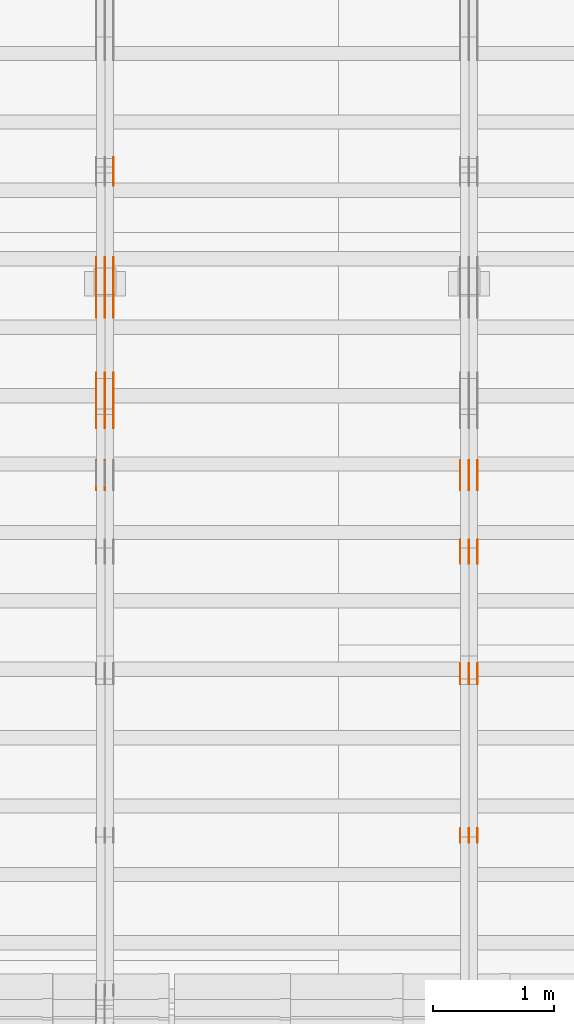
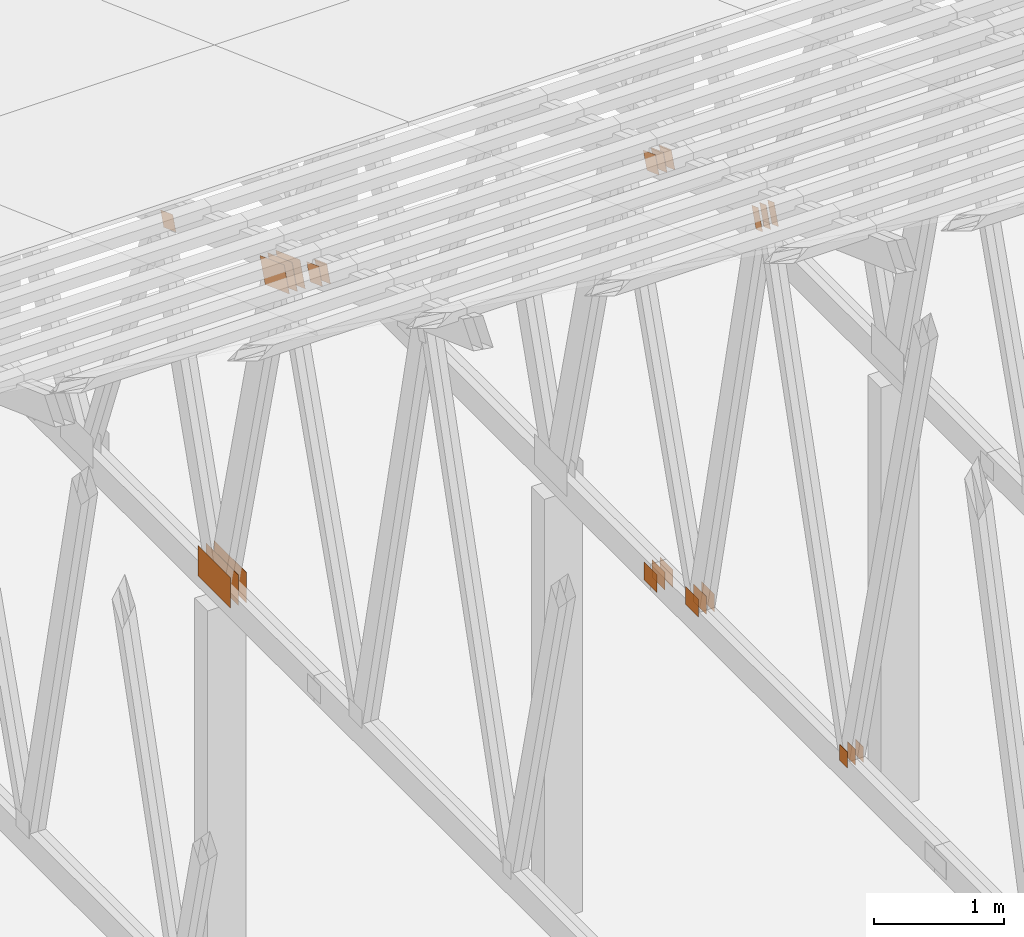
# One storey, part 109 of 189: 31 proxies.
"""IFC2X3 building model written with IfcOpenShell, lengths in millimetres."""

import ifcopenshell
import ifcopenshell.guid

model = None  # the IFC model being written
_history = None  # IfcOwnerHistory: only IFC2X3 demands one
_inside = {}  # id of a spatial element -> (the spatial element, [elements in it])
_under = {}  # id of a project, library or spatial element -> (it, [spatial elements below it])
_declared = {}  # id of a project -> (the project, [libraries it declares])
_typed = {}  # id of a type object -> (the type object, [elements of that type])
_made_of = {}  # id of a material, layer set ... -> (it, [elements and type objects made of it])


def new_model(schema):
    """Start an empty IFC model of exactly this schema.

    Asked for "IFC4X3", IfcOpenShell would pick the latest addendum, in which some entities
    have other attributes; the version numbers below select the first issue.
    IFC2X3 requires an IfcOwnerHistory on every rooted entity: one is made here for all.
    """
    global model, _history
    if schema == "IFC4X3":
        model = ifcopenshell.file(schema_version=(4, 3, 0, 0))
    else:
        model = ifcopenshell.file(schema=schema)
    _inside.clear()
    _under.clear()
    _declared.clear()
    _typed.clear()
    _made_of.clear()
    _history = None
    if model.schema == "IFC2X3":
        org = make("IfcOrganization", Name="unknown")
        user = make(
            "IfcPersonAndOrganization",
            ThePerson=make("IfcPerson", FamilyName="unknown"),
            TheOrganization=org,
        )
        app = make(
            "IfcApplication",
            ApplicationDeveloper=org,
            Version="unknown",
            ApplicationFullName="unknown",
            ApplicationIdentifier="unknown",
        )
        _history = make(
            "IfcOwnerHistory",
            OwningUser=user,
            OwningApplication=app,
            ChangeAction="ADDED",
            CreationDate=0,
        )
    return model


def make(cls, **values):
    """One entity of the class cls with the attributes given. An attribute that is None is left unset."""
    return model.create_entity(
        cls, **{name: value for name, value in values.items() if value is not None}
    )


def entity(cls, *values):
    """Any entity or typed value of the class cls, its attributes in the order of the schema. None: left unset."""
    e = model.create_entity(cls)
    for i, value in enumerate(values):
        if value is not None:
            e[i] = value
    return e


def rooted(cls, **values):
    """An entity with a GlobalId (a new one), such as an element, a storey or a relation."""
    return make(cls, GlobalId=ifcopenshell.guid.new(), OwnerHistory=_history, **values)


def si_unit(unit_type, name, prefix=None):
    """IfcSIUnit, for example si_unit("LENGTHUNIT", "METRE", prefix="MILLI")."""
    return make("IfcSIUnit", UnitType=unit_type, Prefix=prefix, Name=name)


def converted_unit(unit_type, name, factor, base, dimensions=None, offset=None):
    """IfcConversionBasedUnit, such as the inch: factor (a typed value) times the base unit."""
    return make(
        "IfcConversionBasedUnit"
        if offset is None
        else "IfcConversionBasedUnitWithOffset",
        ConversionOffset=offset,
        Dimensions=None
        if dimensions is None
        else entity("IfcDimensionalExponents", *dimensions),
        UnitType=unit_type,
        Name=name,
        ConversionFactor=make(
            "IfcMeasureWithUnit", ValueComponent=factor, UnitComponent=base
        ),
    )


def derived_unit(unit_type, elements):
    """IfcDerivedUnit: a product of units, each with its exponent."""
    return make(
        "IfcDerivedUnit",
        Elements=[
            make("IfcDerivedUnitElement", Unit=unit, Exponent=power)
            for unit, power in elements
        ],
        UnitType=unit_type,
    )


def assignment(units):
    """IfcUnitAssignment: the units of a project."""
    return None if units is None else make("IfcUnitAssignment", Units=units)


def point(xyz):
    """IfcCartesianPoint."""
    return None if xyz is None else make("IfcCartesianPoint", Coordinates=xyz)


def direction(xyz):
    """IfcDirection."""
    return None if xyz is None else make("IfcDirection", DirectionRatios=xyz)


def frame(location, z_axis=None, x_axis=None):
    """IfcAxis2Placement3D, a coordinate frame: its origin and axes. An axis left out is left unset."""
    return make(
        "IfcAxis2Placement3D",
        Location=point(location),
        Axis=direction(z_axis),
        RefDirection=direction(x_axis),
    )


def frame_2d(location, x_axis=None):
    """IfcAxis2Placement2D, a coordinate frame in the plane: its origin and x axis."""
    return make(
        "IfcAxis2Placement2D", Location=point(location), RefDirection=direction(x_axis)
    )


def origin():
    """The frame at (0, 0, 0) with its axes left unset."""
    return frame((0.0, 0.0, 0.0))


def origin_2d_with_axis():
    """The frame at (0, 0) in the plane with the x axis (1, 0) written out."""
    return frame_2d((0.0, 0.0), x_axis=(1.0, 0.0))


def place(relative_to, where):
    """IfcLocalPlacement: puts the frame where relative to a parent placement (None: the world)."""
    return make(
        "IfcLocalPlacement", PlacementRelTo=relative_to, RelativePlacement=where
    )


def context(
    kind, dimensions, precision=None, world=None, true_north=None, identifier=None
):
    """IfcGeometricRepresentationContext, for example the 3D "Model" context."""
    return make(
        "IfcGeometricRepresentationContext",
        ContextIdentifier=identifier,
        ContextType=kind,
        CoordinateSpaceDimension=dimensions,
        Precision=precision,
        WorldCoordinateSystem=world,
        TrueNorth=true_north,
    )


def subcontext(parent, identifier, kind, view, scale=None):
    """IfcGeometricRepresentationSubContext, for example "Body" below "Model"."""
    return make(
        "IfcGeometricRepresentationSubContext",
        ContextIdentifier=identifier,
        ContextType=kind,
        ParentContext=parent,
        TargetScale=scale,
        TargetView=view,
    )


def project(units=None, contexts=None):
    """IfcProject with its units and contexts."""
    return rooted(
        "IfcProject",
        Name="project",
        RepresentationContexts=contexts,
        UnitsInContext=assignment(units),
    )


def spatial(cls, under=None, at=None, **own):
    """A site, building, storey or space (cls), placed at a placement, below another one or the project."""
    s = rooted(cls, ObjectPlacement=at, **own)
    if under is not None:
        _under.setdefault(under.id(), (under, []))[1].append(s)
    return s


def polyline(points):
    """IfcPolyline through the points."""
    return make("IfcPolyline", Points=[point(p) for p in points])


def profile(cls, at=None, kind="AREA", **sizes):
    """A parametric profile (cls). Its sizes go by their IFC names, for example OverallWidth=200.0."""
    return make(cls, ProfileType=kind, Position=at, **sizes)


def rectangle(**sizes):
    """IfcRectangleProfileDef."""
    return profile("IfcRectangleProfileDef", **sizes)


def outline(outer, holes=None, kind="AREA"):
    """IfcArbitraryClosedProfileDef: a profile drawn as a closed curve; with holes, ...WithVoids."""
    if holes is None:
        return make("IfcArbitraryClosedProfileDef", ProfileType=kind, OuterCurve=outer)
    return make(
        "IfcArbitraryProfileDefWithVoids",
        ProfileType=kind,
        OuterCurve=outer,
        InnerCurves=holes,
    )


def extrude(swept, where, along, depth):
    """IfcExtrudedAreaSolid: the profile swept, set in the frame where, extruded along a direction by depth."""
    return make(
        "IfcExtrudedAreaSolid",
        SweptArea=swept,
        Position=where,
        ExtrudedDirection=direction(along),
        Depth=depth,
    )


def shape(context_of_items, identifier, shape_type, items):
    """IfcShapeRepresentation: the items that make up one representation, for example the "Body"."""
    return make(
        "IfcShapeRepresentation",
        ContextOfItems=context_of_items,
        RepresentationIdentifier=identifier,
        RepresentationType=shape_type,
        Items=items,
    )


def source(mapping_origin, context_of_items, identifier, shape_type, items):
    """IfcRepresentationMap: a shape defined once, which mapped items show again and again."""
    return make(
        "IfcRepresentationMap",
        MappingOrigin=mapping_origin,
        MappedRepresentation=shape(context_of_items, identifier, shape_type, items),
    )


def transform(
    local_origin,
    x_axis=None,
    y_axis=None,
    z_axis=None,
    scale=None,
    scale2=None,
    scale3=None,
    uniform=True,
):
    """IfcCartesianTransformationOperator3D, or its non-uniform kind. x_axis, y_axis, z_axis: its Axis1, 2, 3."""
    if uniform:
        return make(
            "IfcCartesianTransformationOperator3D",
            Axis1=direction(x_axis),
            Axis2=direction(y_axis),
            LocalOrigin=point(local_origin),
            Scale=scale,
            Axis3=direction(z_axis),
        )
    return make(
        "IfcCartesianTransformationOperator3DnonUniform",
        Axis1=direction(x_axis),
        Axis2=direction(y_axis),
        LocalOrigin=point(local_origin),
        Scale=scale,
        Axis3=direction(z_axis),
        Scale2=scale2,
        Scale3=scale3,
    )


def mapped(mapping_source, mapping_target):
    """IfcMappedItem: shows the shape of a source again, moved by a transform."""
    return make(
        "IfcMappedItem", MappingSource=mapping_source, MappingTarget=mapping_target
    )


def material(Name=None, Category=None):
    """IfcMaterial."""
    return make("IfcMaterial", Name=Name, Category=Category)


def made_of(thing, what):
    """Note that an element or type object is made of a material, layer set ...; save() writes the relation."""
    if what is not None:
        _made_of.setdefault(what.id(), (what, []))[1].append(thing)
    return thing


def type_object(cls, material=None, **own):
    """A type object (cls), such as IfcWallType, which elements share."""
    return made_of(rooted(cls, **own), material)


def type_shapes(of_type, sources):
    """Give a type object the sources (RepresentationMaps) that its elements show as mapped items."""
    of_type.RepresentationMaps = sources


def element(
    cls,
    number,
    at=None,
    inside=None,
    cuts=None,
    type_object=None,
    material=None,
    context=None,
    identifier="Body",
    shape_type=None,
    held_by="IfcProductDefinitionShape",
    body=None,
    shapes=None,
    **own,
):
    """One element of the class cls, such as IfcWall. Its Tag is "e" and its number.

    at: its placement. inside: the storey or other place that contains it. cuts: it is an
    opening in that element (IfcRelVoidsElement). A single representation is given by context,
    identifier, shape_type and body (its items); several are given by shapes. held_by: the class
    of the entity that holds the representations. save() writes the other relations.
    """
    e = rooted(cls, Tag="e%d" % number, ObjectPlacement=at, **own)
    if body is not None:
        shapes = [shape(context, identifier, shape_type, body)]
    if shapes is not None:
        e.Representation = make(held_by, Representations=shapes)
    if inside is not None:
        _inside.setdefault(inside.id(), (inside, []))[1].append(e)
    if cuts is not None:
        rooted(
            "IfcRelVoidsElement", RelatingBuildingElement=cuts, RelatedOpeningElement=e
        )
    if type_object is not None:
        _typed.setdefault(type_object.id(), (type_object, []))[1].append(e)
    return made_of(e, material)


def aggregate(whole, parts):
    """IfcRelAggregates: a whole, such as a stair, and the parts it consists of."""
    return rooted("IfcRelAggregates", RelatingObject=whole, RelatedObjects=parts)


def save(model, path):
    """Write the relations noted so far, then the file.

    IfcRelAggregates (storeys below a building ...), IfcRelContainedInSpatialStructure (elements
    in a storey), IfcRelDefinesByType, IfcRelAssociatesMaterial and IfcRelDeclares: one each for
    every whole, place, type object, material and project.
    """
    for whole, parts in _under.values():
        aggregate(whole, parts)
    for where, things in _inside.values():
        rooted(
            "IfcRelContainedInSpatialStructure",
            RelatedElements=things,
            RelatingStructure=where,
        )
    for kind, things in _typed.values():
        rooted("IfcRelDefinesByType", RelatedObjects=things, RelatingType=kind)
    for what, things in _made_of.values():
        rooted("IfcRelAssociatesMaterial", RelatedObjects=things, RelatingMaterial=what)
    for by, libraries in _declared.values():
        rooted("IfcRelDeclares", RelatingContext=by, RelatedDefinitions=libraries)
    model.write(path)


model = new_model("IFC2X3")

# Units and contexts
model_context = context("Model", 3, precision=0.01, world=origin(), true_north=direction((6.12303176911189e-17, 1.0)))
body_context = subcontext(model_context, "Body", "Model", "MODEL_VIEW")
ifc_project = project(units=[si_unit("LENGTHUNIT", "METRE", prefix="MILLI"), si_unit("AREAUNIT", "SQUARE_METRE"), si_unit("VOLUMEUNIT", "CUBIC_METRE"), converted_unit("PLANEANGLEUNIT", "DEGREE", entity("IfcRatioMeasure", 0.0174532925199433), si_unit("PLANEANGLEUNIT", "RADIAN"), dimensions=[0, 0, 0, 0, 0, 0, 0]), si_unit("MASSUNIT", "GRAM", prefix="KILO"), derived_unit("MASSDENSITYUNIT", [(si_unit("MASSUNIT", "GRAM", prefix="KILO"), 1), (si_unit("LENGTHUNIT", "METRE"), -3)]), si_unit("TIMEUNIT", "SECOND"), si_unit("FREQUENCYUNIT", "HERTZ"), si_unit("THERMODYNAMICTEMPERATUREUNIT", "DEGREE_CELSIUS"), derived_unit("THERMALTRANSMITTANCEUNIT", [(si_unit("MASSUNIT", "GRAM", prefix="KILO"), 1), (si_unit("THERMODYNAMICTEMPERATUREUNIT", "KELVIN"), -1), (si_unit("TIMEUNIT", "SECOND"), -3)]), derived_unit("VOLUMETRICFLOWRATEUNIT", [(si_unit("LENGTHUNIT", "METRE"), 3), (si_unit("TIMEUNIT", "SECOND"), -1)]), si_unit("ELECTRICCURRENTUNIT", "AMPERE"), si_unit("ELECTRICVOLTAGEUNIT", "VOLT"), si_unit("POWERUNIT", "WATT"), si_unit("FORCEUNIT", "NEWTON"), si_unit("ILLUMINANCEUNIT", "LUX"), si_unit("LUMINOUSFLUXUNIT", "LUMEN"), si_unit("LUMINOUSINTENSITYUNIT", "CANDELA"), derived_unit("USERDEFINED", [(si_unit("MASSUNIT", "GRAM", prefix="KILO"), -1), (si_unit("LENGTHUNIT", "METRE"), -2), (si_unit("TIMEUNIT", "SECOND"), 3), (si_unit("LUMINOUSFLUXUNIT", "LUMEN"), 1)]), derived_unit("LINEARVELOCITYUNIT", [(si_unit("LENGTHUNIT", "METRE"), 1), (si_unit("TIMEUNIT", "SECOND"), -1)]), si_unit("PRESSUREUNIT", "PASCAL"), derived_unit("USERDEFINED", [(si_unit("LENGTHUNIT", "METRE"), -2), (si_unit("MASSUNIT", "GRAM", prefix="KILO"), 1), (si_unit("TIMEUNIT", "SECOND"), -2)])], contexts=[model_context])

# Site, building, storey
site_placement = place(None, origin())
site = spatial("IfcSite", under=ifc_project, at=site_placement, CompositionType="ELEMENT")
building_placement = place(site_placement, origin())
building = spatial("IfcBuilding", under=site, at=building_placement, CompositionType="ELEMENT")
storey_placement = place(building_placement, origin())
storey = spatial("IfcBuildingStorey", under=building, at=storey_placement, Name="Default", CompositionType="ELEMENT", Elevation=0.0)

# Proxies
ifc_material_1 = material(Name="IfcSurfaceStyle #78546")
building_element_proxy_type_1 = type_object("IfcBuildingElementProxyType", PredefinedType="NOTDEFINED", material=ifc_material_1)
shared_shape_1 = source(origin(), body_context, "Body", "SweptSolid", [
    extrude(rectangle(XDim=150.0, YDim=120.0, at=origin_2d_with_axis()), frame((75.0, 60.0, 0.0), z_axis=(0.0, 0.0, 1.0), x_axis=(-1.0, 0.0, 0.0)), (0.0, 0.0, 1.0), 1.3),
])
type_shapes(building_element_proxy_type_1, [shared_shape_1])
proxy_1_placement = place(building_placement, frame((12301.3, 16120.724609375, 170.0), z_axis=(-1.0, 0.0, 0.0), x_axis=(0.0, 0.0, 1.0)))
element("IfcBuildingElementProxy", 1, at=proxy_1_placement, inside=storey, type_object=building_element_proxy_type_1, material=ifc_material_1, context=body_context, shape_type="MappedRepresentation", body=[
    mapped(shared_shape_1, transform((0.0, 0.0, 0.0), scale=1.0)),
])
ifc_material_2 = material(Name="IfcSurfaceStyle #78489")
building_element_proxy_type_2 = type_object("IfcBuildingElementProxyType", PredefinedType="NOTDEFINED", material=ifc_material_2)
shared_shape_2 = source(origin(), body_context, "Body", "SweptSolid", [
    extrude(rectangle(XDim=150.0, YDim=120.0, at=origin_2d_with_axis()), frame((75.0, 60.0, 0.0), z_axis=(0.0, 0.0, 1.0), x_axis=(-1.0, 0.0, 0.0)), (0.0, 0.0, 1.0), 1.29999999999999),
])
type_shapes(building_element_proxy_type_2, [shared_shape_2])
proxy_2_placement = place(building_placement, frame((12230.0, 16120.724609375, 170.0), z_axis=(-1.0, 0.0, 0.0), x_axis=(0.0, 0.0, 1.0)))
element("IfcBuildingElementProxy", 2, at=proxy_2_placement, inside=storey, type_object=building_element_proxy_type_2, material=ifc_material_2, context=body_context, shape_type="MappedRepresentation", body=[
    mapped(shared_shape_2, transform((0.0, 0.0, 0.0), scale=1.0)),
])
ifc_material_3 = material(Name="IfcSurfaceStyle #78432")
building_element_proxy_type_3 = type_object("IfcBuildingElementProxyType", PredefinedType="NOTDEFINED", material=ifc_material_3)
shared_shape_3 = source(origin(), body_context, "Body", "SweptSolid", [
    extrude(rectangle(XDim=150.0, YDim=120.0, at=origin_2d_with_axis()), frame((75.0, 60.0, 0.0), z_axis=(0.0, 0.0, 1.0), x_axis=(-1.0, 0.0, 0.0)), (0.0, 0.0, 1.0), 1.29999999999999),
])
type_shapes(building_element_proxy_type_3, [shared_shape_3])
proxy_3_placement = place(building_placement, frame((12231.3, 16120.724609375, 170.0), z_axis=(-1.0, 0.0, 0.0), x_axis=(0.0, 0.0, 1.0)))
element("IfcBuildingElementProxy", 3, at=proxy_3_placement, inside=storey, type_object=building_element_proxy_type_3, material=ifc_material_3, context=body_context, shape_type="MappedRepresentation", body=[
    mapped(shared_shape_3, transform((0.0, 0.0, 0.0), scale=1.0)),
])
ifc_material_4 = material(Name="IfcSurfaceStyle #78375")
building_element_proxy_type_4 = type_object("IfcBuildingElementProxyType", PredefinedType="NOTDEFINED", material=ifc_material_4)
shared_shape_4 = source(origin(), body_context, "Body", "SweptSolid", [
    extrude(rectangle(XDim=150.0, YDim=120.0, at=origin_2d_with_axis()), frame((75.0, 60.0, 0.0), z_axis=(0.0, 0.0, 1.0), x_axis=(-1.0, 0.0, 0.0)), (0.0, 0.0, 1.0), 1.29999999999999),
])
type_shapes(building_element_proxy_type_4, [shared_shape_4])
proxy_4_placement = place(building_placement, frame((12160.0, 16120.724609375, 170.0), z_axis=(-1.0, 0.0, 0.0), x_axis=(0.0, 0.0, 1.0)))
element("IfcBuildingElementProxy", 4, at=proxy_4_placement, inside=storey, type_object=building_element_proxy_type_4, material=ifc_material_4, context=body_context, shape_type="MappedRepresentation", body=[
    mapped(shared_shape_4, transform((0.0, 0.0, 0.0), scale=1.0)),
])
ifc_material_5 = material(Name="IfcSurfaceStyle #77406")
building_element_proxy_type_5 = type_object("IfcBuildingElementProxyType", PredefinedType="NOTDEFINED", material=ifc_material_5)
shared_shape_5 = source(origin(), body_context, "Body", "SweptSolid", [
    extrude(outline(polyline([(-99.9998320329903, -54.0001530266309), (99.9998809717702, -54.0001530266309), (100.000228452157, 54.0001530266309), (-100.000277390937, 54.0001530266309), (-99.9998320329903, -54.0001530266309)])), frame((100.000228452157, 54.0002543377796, 0.0), z_axis=(0.0, 0.0, 1.0), x_axis=(-1.0, 0.0, 0.0)), (0.0, 0.0, 1.0), 1.3),
])
type_shapes(building_element_proxy_type_5, [shared_shape_5])
proxy_5_placement = place(building_placement, frame((12301.3, 17599.4482421875, 4577.14111328125), z_axis=(-1.0, 0.0, 0.0), x_axis=(0.0, -0.342020143325669, -0.939692620785908)))
element("IfcBuildingElementProxy", 5, at=proxy_5_placement, inside=storey, type_object=building_element_proxy_type_5, material=ifc_material_5, context=body_context, shape_type="MappedRepresentation", body=[
    mapped(shared_shape_5, transform((0.0, 0.0, 0.0), scale=1.0)),
])
ifc_material_6 = material(Name="IfcSurfaceStyle #77349")
building_element_proxy_type_6 = type_object("IfcBuildingElementProxyType", PredefinedType="NOTDEFINED", material=ifc_material_6)
shared_shape_6 = source(origin(), body_context, "Body", "SweptSolid", [
    extrude(outline(polyline([(-99.9998320329903, -54.0001530266309), (99.9998809717702, -54.0001530266309), (100.000228452157, 54.0001530266309), (-100.000277390937, 54.0001530266309), (-99.9998320329903, -54.0001530266309)])), frame((100.000228452157, 54.0002543377796, 0.0), z_axis=(0.0, 0.0, 1.0), x_axis=(-1.0, 0.0, 0.0)), (0.0, 0.0, 1.0), 1.29999999999998),
])
type_shapes(building_element_proxy_type_6, [shared_shape_6])
proxy_6_placement = place(building_placement, frame((12230.0, 17599.4482421875, 4577.14111328125), z_axis=(-1.0, 0.0, 0.0), x_axis=(0.0, -0.342020143325669, -0.939692620785908)))
element("IfcBuildingElementProxy", 6, at=proxy_6_placement, inside=storey, type_object=building_element_proxy_type_6, material=ifc_material_6, context=body_context, shape_type="MappedRepresentation", body=[
    mapped(shared_shape_6, transform((0.0, 0.0, 0.0), scale=1.0)),
])
ifc_material_7 = material(Name="IfcSurfaceStyle #77292")
building_element_proxy_type_7 = type_object("IfcBuildingElementProxyType", PredefinedType="NOTDEFINED", material=ifc_material_7)
shared_shape_7 = source(origin(), body_context, "Body", "SweptSolid", [
    extrude(outline(polyline([(-99.9998320329903, -54.0001530266309), (99.9998809717702, -54.0001530266309), (100.000228452157, 54.0001530266309), (-100.000277390937, 54.0001530266309), (-99.9998320329903, -54.0001530266309)])), frame((100.000228452157, 54.0002543377796, 0.0), z_axis=(0.0, 0.0, 1.0), x_axis=(-1.0, 0.0, 0.0)), (0.0, 0.0, 1.0), 1.29999999999998),
])
type_shapes(building_element_proxy_type_7, [shared_shape_7])
proxy_7_placement = place(building_placement, frame((12231.3, 17599.4482421875, 4577.14111328125), z_axis=(-1.0, 0.0, 0.0), x_axis=(0.0, -0.342020143325669, -0.939692620785908)))
element("IfcBuildingElementProxy", 7, at=proxy_7_placement, inside=storey, type_object=building_element_proxy_type_7, material=ifc_material_7, context=body_context, shape_type="MappedRepresentation", body=[
    mapped(shared_shape_7, transform((0.0, 0.0, 0.0), scale=1.0)),
])
ifc_material_8 = material(Name="IfcSurfaceStyle #77235")
building_element_proxy_type_8 = type_object("IfcBuildingElementProxyType", PredefinedType="NOTDEFINED", material=ifc_material_8)
shared_shape_8 = source(origin(), body_context, "Body", "SweptSolid", [
    extrude(outline(polyline([(-99.9998320329903, -54.0001530266309), (99.9998809717702, -54.0001530266309), (100.000228452157, 54.0001530266309), (-100.000277390937, 54.0001530266309), (-99.9998320329903, -54.0001530266309)])), frame((100.000228452157, 54.0002543377796, 0.0), z_axis=(0.0, 0.0, 1.0), x_axis=(-1.0, 0.0, 0.0)), (0.0, 0.0, 1.0), 1.29999999999999),
])
type_shapes(building_element_proxy_type_8, [shared_shape_8])
proxy_8_placement = place(building_placement, frame((12160.0, 17599.4482421875, 4577.14111328125), z_axis=(-1.0, 0.0, 0.0), x_axis=(0.0, -0.342020143325669, -0.939692620785908)))
element("IfcBuildingElementProxy", 8, at=proxy_8_placement, inside=storey, type_object=building_element_proxy_type_8, material=ifc_material_8, context=body_context, shape_type="MappedRepresentation", body=[
    mapped(shared_shape_8, transform((0.0, 0.0, 0.0), scale=1.0)),
])
ifc_material_9 = material(Name="IfcSurfaceStyle #77178")
building_element_proxy_type_9 = type_object("IfcBuildingElementProxyType", PredefinedType="NOTDEFINED", material=ifc_material_9)
shared_shape_9 = source(origin(), body_context, "Body", "SweptSolid", [
    extrude(rectangle(XDim=200.0, YDim=168.0, at=origin_2d_with_axis()), frame((100.0, 84.0, 0.0), z_axis=(0.0, 0.0, 1.0), x_axis=(-1.0, 0.0, 0.0)), (0.0, 0.0, 1.0), 1.3),
])
type_shapes(building_element_proxy_type_9, [shared_shape_9])
proxy_9_placement = place(building_placement, frame((12301.3, 18619.8427734375, 197.0), z_axis=(-1.0, 0.0, 0.0), x_axis=(0.0, -1.0, 0.0)))
element("IfcBuildingElementProxy", 9, at=proxy_9_placement, inside=storey, type_object=building_element_proxy_type_9, material=ifc_material_9, context=body_context, shape_type="MappedRepresentation", body=[
    mapped(shared_shape_9, transform((0.0, 0.0, 0.0), scale=1.0)),
])
ifc_material_10 = material(Name="IfcSurfaceStyle #77121")
building_element_proxy_type_10 = type_object("IfcBuildingElementProxyType", PredefinedType="NOTDEFINED", material=ifc_material_10)
shared_shape_10 = source(origin(), body_context, "Body", "SweptSolid", [
    extrude(rectangle(XDim=200.0, YDim=168.0, at=origin_2d_with_axis()), frame((100.0, 84.0, 0.0), z_axis=(0.0, 0.0, 1.0), x_axis=(-1.0, 0.0, 0.0)), (0.0, 0.0, 1.0), 1.29999999999998),
])
type_shapes(building_element_proxy_type_10, [shared_shape_10])
proxy_10_placement = place(building_placement, frame((12230.0, 18619.8427734375, 197.0), z_axis=(-1.0, 0.0, 0.0), x_axis=(0.0, -1.0, 0.0)))
element("IfcBuildingElementProxy", 10, at=proxy_10_placement, inside=storey, type_object=building_element_proxy_type_10, material=ifc_material_10, context=body_context, shape_type="MappedRepresentation", body=[
    mapped(shared_shape_10, transform((0.0, 0.0, 0.0), scale=1.0)),
])
ifc_material_11 = material(Name="IfcSurfaceStyle #77064")
building_element_proxy_type_11 = type_object("IfcBuildingElementProxyType", PredefinedType="NOTDEFINED", material=ifc_material_11)
shared_shape_11 = source(origin(), body_context, "Body", "SweptSolid", [
    extrude(rectangle(XDim=200.0, YDim=168.0, at=origin_2d_with_axis()), frame((100.0, 84.0, 0.0), z_axis=(0.0, 0.0, 1.0), x_axis=(-1.0, 0.0, 0.0)), (0.0, 0.0, 1.0), 1.29999999999998),
])
type_shapes(building_element_proxy_type_11, [shared_shape_11])
proxy_11_placement = place(building_placement, frame((12231.3, 18619.8427734375, 197.0), z_axis=(-1.0, 0.0, 0.0), x_axis=(0.0, -1.0, 0.0)))
element("IfcBuildingElementProxy", 11, at=proxy_11_placement, inside=storey, type_object=building_element_proxy_type_11, material=ifc_material_11, context=body_context, shape_type="MappedRepresentation", body=[
    mapped(shared_shape_11, transform((0.0, 0.0, 0.0), scale=1.0)),
])
ifc_material_12 = material(Name="IfcSurfaceStyle #77007")
building_element_proxy_type_12 = type_object("IfcBuildingElementProxyType", PredefinedType="NOTDEFINED", material=ifc_material_12)
shared_shape_12 = source(origin(), body_context, "Body", "SweptSolid", [
    extrude(rectangle(XDim=200.0, YDim=168.0, at=origin_2d_with_axis()), frame((100.0, 84.0, 0.0), z_axis=(0.0, 0.0, 1.0), x_axis=(-1.0, 0.0, 0.0)), (0.0, 0.0, 1.0), 1.29999999999999),
])
type_shapes(building_element_proxy_type_12, [shared_shape_12])
proxy_12_placement = place(building_placement, frame((12160.0, 18619.8427734375, 197.0), z_axis=(-1.0, 0.0, 0.0), x_axis=(0.0, -1.0, 0.0)))
element("IfcBuildingElementProxy", 12, at=proxy_12_placement, inside=storey, type_object=building_element_proxy_type_12, material=ifc_material_12, context=body_context, shape_type="MappedRepresentation", body=[
    mapped(shared_shape_12, transform((0.0, 0.0, 0.0), scale=1.0)),
])
ifc_material_13 = material(Name="IfcSurfaceStyle #71250")
building_element_proxy_type_13 = type_object("IfcBuildingElementProxyType", PredefinedType="NOTDEFINED", material=ifc_material_13)
shared_shape_13 = source(origin(), body_context, "Body", "SweptSolid", [
    extrude(rectangle(XDim=200.0, YDim=168.0, at=origin_2d_with_axis()), frame((100.0, 84.0, 0.0), z_axis=(0.0, 0.0, 1.0), x_axis=(-1.0, 0.0, 0.0)), (0.0, 0.0, 1.0), 1.3),
])
type_shapes(building_element_proxy_type_13, [shared_shape_13])
proxy_13_placement = place(building_placement, frame((12301.3, 19061.7587890625, 206.5), z_axis=(-1.0, 0.0, 0.0), x_axis=(0.0, 1.0, 0.0)))
element("IfcBuildingElementProxy", 13, at=proxy_13_placement, inside=storey, type_object=building_element_proxy_type_13, material=ifc_material_13, context=body_context, shape_type="MappedRepresentation", body=[
    mapped(shared_shape_13, transform((0.0, 0.0, 0.0), scale=1.0)),
])
ifc_material_14 = material(Name="IfcSurfaceStyle #71193")
building_element_proxy_type_14 = type_object("IfcBuildingElementProxyType", PredefinedType="NOTDEFINED", material=ifc_material_14)
shared_shape_14 = source(origin(), body_context, "Body", "SweptSolid", [
    extrude(rectangle(XDim=200.0, YDim=168.0, at=origin_2d_with_axis()), frame((100.0, 84.0, 0.0), z_axis=(0.0, 0.0, 1.0), x_axis=(-1.0, 0.0, 0.0)), (0.0, 0.0, 1.0), 1.29999999999998),
])
type_shapes(building_element_proxy_type_14, [shared_shape_14])
proxy_14_placement = place(building_placement, frame((12230.0, 19061.7587890625, 206.5), z_axis=(-1.0, 0.0, 0.0), x_axis=(0.0, 1.0, 0.0)))
element("IfcBuildingElementProxy", 14, at=proxy_14_placement, inside=storey, type_object=building_element_proxy_type_14, material=ifc_material_14, context=body_context, shape_type="MappedRepresentation", body=[
    mapped(shared_shape_14, transform((0.0, 0.0, 0.0), scale=1.0)),
])
ifc_material_15 = material(Name="IfcSurfaceStyle #71136")
building_element_proxy_type_15 = type_object("IfcBuildingElementProxyType", PredefinedType="NOTDEFINED", material=ifc_material_15)
shared_shape_15 = source(origin(), body_context, "Body", "SweptSolid", [
    extrude(rectangle(XDim=200.0, YDim=168.0, at=origin_2d_with_axis()), frame((100.0, 84.0, 0.0), z_axis=(0.0, 0.0, 1.0), x_axis=(-1.0, 0.0, 0.0)), (0.0, 0.0, 1.0), 1.29999999999998),
])
type_shapes(building_element_proxy_type_15, [shared_shape_15])
proxy_15_placement = place(building_placement, frame((12231.3, 19061.7587890625, 206.5), z_axis=(-1.0, 0.0, 0.0), x_axis=(0.0, 1.0, 0.0)))
element("IfcBuildingElementProxy", 15, at=proxy_15_placement, inside=storey, type_object=building_element_proxy_type_15, material=ifc_material_15, context=body_context, shape_type="MappedRepresentation", body=[
    mapped(shared_shape_15, transform((0.0, 0.0, 0.0), scale=1.0)),
])
ifc_material_16 = material(Name="IfcSurfaceStyle #71079")
building_element_proxy_type_16 = type_object("IfcBuildingElementProxyType", PredefinedType="NOTDEFINED", material=ifc_material_16)
shared_shape_16 = source(origin(), body_context, "Body", "SweptSolid", [
    extrude(rectangle(XDim=200.0, YDim=168.0, at=origin_2d_with_axis()), frame((100.0, 84.0, 0.0), z_axis=(0.0, 0.0, 1.0), x_axis=(-1.0, 0.0, 0.0)), (0.0, 0.0, 1.0), 1.29999999999999),
])
type_shapes(building_element_proxy_type_16, [shared_shape_16])
proxy_16_placement = place(building_placement, frame((12160.0, 19061.7587890625, 206.5), z_axis=(-1.0, 0.0, 0.0), x_axis=(0.0, 1.0, 0.0)))
element("IfcBuildingElementProxy", 16, at=proxy_16_placement, inside=storey, type_object=building_element_proxy_type_16, material=ifc_material_16, context=body_context, shape_type="MappedRepresentation", body=[
    mapped(shared_shape_16, transform((0.0, 0.0, 0.0), scale=1.0)),
])
ifc_material_17 = material(Name="IfcSurfaceStyle #69090")
building_element_proxy_type_17 = type_object("IfcBuildingElementProxyType", PredefinedType="NOTDEFINED", material=ifc_material_17)
shared_shape_17 = source(origin(), body_context, "Body", "SweptSolid", [
    extrude(outline(polyline([(-100.000115120732, -83.9999347094754), (99.9997648860521, -83.9999347094754), (100.000156871236, 83.9999347094753), (-99.9998066365565, 83.9999347094753), (-100.000115120732, -83.9999347094754)])), frame((100.000156871236, 84.0000502182443, 0.0), z_axis=(0.0, 0.0, 1.0), x_axis=(-1.0, 0.0, 0.0)), (0.0, 0.0, 1.0), 1.3),
])
type_shapes(building_element_proxy_type_17, [shared_shape_17])
proxy_17_placement = place(building_placement, frame((12301.3, 19216.0995831719, 3923.28093386695), z_axis=(-1.0, 0.0, 0.0), x_axis=(0.0, -0.939692620785908, 0.342020143325669)))
element("IfcBuildingElementProxy", 17, at=proxy_17_placement, inside=storey, type_object=building_element_proxy_type_17, material=ifc_material_17, context=body_context, shape_type="MappedRepresentation", body=[
    mapped(shared_shape_17, transform((0.0, 0.0, 0.0), scale=1.0)),
])
ifc_material_18 = material(Name="IfcSurfaceStyle #69033")
building_element_proxy_type_18 = type_object("IfcBuildingElementProxyType", PredefinedType="NOTDEFINED", material=ifc_material_18)
shared_shape_18 = source(origin(), body_context, "Body", "SweptSolid", [
    extrude(outline(polyline([(-100.000115120732, -83.9999347094754), (99.9997648860521, -83.9999347094754), (100.000156871236, 83.9999347094753), (-99.9998066365565, 83.9999347094753), (-100.000115120732, -83.9999347094754)])), frame((100.000156871236, 84.0000502182443, 0.0), z_axis=(0.0, 0.0, 1.0), x_axis=(-1.0, 0.0, 0.0)), (0.0, 0.0, 1.0), 1.29999999999998),
])
type_shapes(building_element_proxy_type_18, [shared_shape_18])
proxy_18_placement = place(building_placement, frame((12230.0, 19216.0995831719, 3923.28093386695), z_axis=(-1.0, 0.0, 0.0), x_axis=(0.0, -0.939692620785908, 0.342020143325669)))
element("IfcBuildingElementProxy", 18, at=proxy_18_placement, inside=storey, type_object=building_element_proxy_type_18, material=ifc_material_18, context=body_context, shape_type="MappedRepresentation", body=[
    mapped(shared_shape_18, transform((0.0, 0.0, 0.0), scale=1.0)),
])
ifc_material_19 = material(Name="IfcSurfaceStyle #68976")
building_element_proxy_type_19 = type_object("IfcBuildingElementProxyType", PredefinedType="NOTDEFINED", material=ifc_material_19)
shared_shape_19 = source(origin(), body_context, "Body", "SweptSolid", [
    extrude(outline(polyline([(-100.000115120732, -83.9999347094754), (99.9997648860521, -83.9999347094754), (100.000156871236, 83.9999347094753), (-99.9998066365565, 83.9999347094753), (-100.000115120732, -83.9999347094754)])), frame((100.000156871236, 84.0000502182443, 0.0), z_axis=(0.0, 0.0, 1.0), x_axis=(-1.0, 0.0, 0.0)), (0.0, 0.0, 1.0), 1.29999999999998),
])
type_shapes(building_element_proxy_type_19, [shared_shape_19])
proxy_19_placement = place(building_placement, frame((12231.3, 19216.0995831719, 3923.28093386695), z_axis=(-1.0, 0.0, 0.0), x_axis=(0.0, -0.939692620785908, 0.342020143325669)))
element("IfcBuildingElementProxy", 19, at=proxy_19_placement, inside=storey, type_object=building_element_proxy_type_19, material=ifc_material_19, context=body_context, shape_type="MappedRepresentation", body=[
    mapped(shared_shape_19, transform((0.0, 0.0, 0.0), scale=1.0)),
])
ifc_material_20 = material(Name="IfcSurfaceStyle #68919")
building_element_proxy_type_20 = type_object("IfcBuildingElementProxyType", PredefinedType="NOTDEFINED", material=ifc_material_20)
shared_shape_20 = source(origin(), body_context, "Body", "SweptSolid", [
    extrude(outline(polyline([(-100.000115120732, -83.9999347094754), (99.9997648860521, -83.9999347094754), (100.000156871236, 83.9999347094753), (-99.9998066365565, 83.9999347094753), (-100.000115120732, -83.9999347094754)])), frame((100.000156871236, 84.0000502182443, 0.0), z_axis=(0.0, 0.0, 1.0), x_axis=(-1.0, 0.0, 0.0)), (0.0, 0.0, 1.0), 1.29999999999999),
])
type_shapes(building_element_proxy_type_20, [shared_shape_20])
proxy_20_placement = place(building_placement, frame((12160.0, 19216.0995831719, 3923.28093386695), z_axis=(-1.0, 0.0, 0.0), x_axis=(0.0, -0.939692620785908, 0.342020143325669)))
element("IfcBuildingElementProxy", 20, at=proxy_20_placement, inside=storey, type_object=building_element_proxy_type_20, material=ifc_material_20, context=body_context, shape_type="MappedRepresentation", body=[
    mapped(shared_shape_20, transform((0.0, 0.0, 0.0), scale=1.0)),
])
ifc_material_21 = material(Name="IfcSurfaceStyle #60704")
building_element_proxy_type_21 = type_object("IfcBuildingElementProxyType", PredefinedType="NOTDEFINED", material=ifc_material_21)
shared_shape_21 = source(origin(), body_context, "Body", "SweptSolid", [
    extrude(outline(polyline([(-200.000344770935, -119.999765965113), (199.999582244654, -119.999765965113), (200.000344770935, 119.999765965113), (-199.999582244653, 119.999765965113), (-200.000344770935, -119.999765965113)])), frame((200.000344770935, 119.999990805307, 0.0), z_axis=(0.0, 0.0, 1.0), x_axis=(-1.0, 0.0, 0.0)), (0.0, 0.0, 1.0), 1.29999999999999),
])
type_shapes(building_element_proxy_type_21, [shared_shape_21])
proxy_21_placement = place(building_placement, frame((9301.3, 19620.1777846684, 3837.77137841443), z_axis=(-1.0, 0.0, 0.0), x_axis=(0.0, 0.939692620785908, -0.342020143325669)))
element("IfcBuildingElementProxy", 21, at=proxy_21_placement, inside=storey, type_object=building_element_proxy_type_21, material=ifc_material_21, context=body_context, shape_type="MappedRepresentation", body=[
    mapped(shared_shape_21, transform((0.0, 0.0, 0.0), scale=1.0)),
])
ifc_material_22 = material(Name="IfcSurfaceStyle #60647")
building_element_proxy_type_22 = type_object("IfcBuildingElementProxyType", PredefinedType="NOTDEFINED", material=ifc_material_22)
shared_shape_22 = source(origin(), body_context, "Body", "SweptSolid", [
    extrude(outline(polyline([(-200.000344770935, -119.999765965113), (199.999582244654, -119.999765965113), (200.000344770935, 119.999765965113), (-199.999582244653, 119.999765965113), (-200.000344770935, -119.999765965113)])), frame((200.000344770935, 119.999990805307, 0.0), z_axis=(0.0, 0.0, 1.0), x_axis=(-1.0, 0.0, 0.0)), (0.0, 0.0, 1.0), 1.29999999999997),
])
type_shapes(building_element_proxy_type_22, [shared_shape_22])
proxy_22_placement = place(building_placement, frame((9230.0, 19620.1777846684, 3837.77137841443), z_axis=(-1.0, 0.0, 0.0), x_axis=(0.0, 0.939692620785908, -0.342020143325669)))
element("IfcBuildingElementProxy", 22, at=proxy_22_placement, inside=storey, type_object=building_element_proxy_type_22, material=ifc_material_22, context=body_context, shape_type="MappedRepresentation", body=[
    mapped(shared_shape_22, transform((0.0, 0.0, 0.0), scale=1.0)),
])
ifc_material_23 = material(Name="IfcSurfaceStyle #60590")
building_element_proxy_type_23 = type_object("IfcBuildingElementProxyType", PredefinedType="NOTDEFINED", material=ifc_material_23)
shared_shape_23 = source(origin(), body_context, "Body", "SweptSolid", [
    extrude(outline(polyline([(-200.000344770935, -119.999765965113), (199.999582244654, -119.999765965113), (200.000344770935, 119.999765965113), (-199.999582244653, 119.999765965113), (-200.000344770935, -119.999765965113)])), frame((200.000344770935, 119.999990805307, 0.0), z_axis=(0.0, 0.0, 1.0), x_axis=(-1.0, 0.0, 0.0)), (0.0, 0.0, 1.0), 1.29999999999997),
])
type_shapes(building_element_proxy_type_23, [shared_shape_23])
proxy_23_placement = place(building_placement, frame((9231.3, 19620.1777846684, 3837.77137841443), z_axis=(-1.0, 0.0, 0.0), x_axis=(0.0, 0.939692620785908, -0.342020143325669)))
element("IfcBuildingElementProxy", 23, at=proxy_23_placement, inside=storey, type_object=building_element_proxy_type_23, material=ifc_material_23, context=body_context, shape_type="MappedRepresentation", body=[
    mapped(shared_shape_23, transform((0.0, 0.0, 0.0), scale=1.0)),
])
ifc_material_24 = material(Name="IfcSurfaceStyle #60533")
building_element_proxy_type_24 = type_object("IfcBuildingElementProxyType", PredefinedType="NOTDEFINED", material=ifc_material_24)
shared_shape_24 = source(origin(), body_context, "Body", "SweptSolid", [
    extrude(outline(polyline([(-200.000344770935, -119.999765965113), (199.999582244654, -119.999765965113), (200.000344770935, 119.999765965113), (-199.999582244653, 119.999765965113), (-200.000344770935, -119.999765965113)])), frame((200.000344770935, 119.999990805307, 0.0), z_axis=(0.0, 0.0, 1.0), x_axis=(-1.0, 0.0, 0.0)), (0.0, 0.0, 1.0), 1.29999999999998),
])
type_shapes(building_element_proxy_type_24, [shared_shape_24])
proxy_24_placement = place(building_placement, frame((9160.0, 19620.1777846684, 3837.77137841443), z_axis=(-1.0, 0.0, 0.0), x_axis=(0.0, 0.939692620785908, -0.342020143325669)))
element("IfcBuildingElementProxy", 24, at=proxy_24_placement, inside=storey, type_object=building_element_proxy_type_24, material=ifc_material_24, context=body_context, shape_type="MappedRepresentation", body=[
    mapped(shared_shape_24, transform((0.0, 0.0, 0.0), scale=1.0)),
])
ifc_material_25 = material(Name="IfcSurfaceStyle #60476")
building_element_proxy_type_25 = type_object("IfcBuildingElementProxyType", PredefinedType="NOTDEFINED", material=ifc_material_25)
shared_shape_25 = source(origin(), body_context, "Body", "SweptSolid", [
    extrude(rectangle(XDim=500.0, YDim=288.0, at=origin_2d_with_axis()), frame((250.0, 144.0, 0.0), z_axis=(0.0, 0.0, 1.0), x_axis=(-1.0, 0.0, 0.0)), (0.0, 0.0, 1.0), 1.29999999999998),
])
type_shapes(building_element_proxy_type_25, [shared_shape_25])
proxy_25_placement = place(building_placement, frame((9301.3, 20948.0908203125, 101.0), z_axis=(-1.0, 0.0, 0.0), x_axis=(0.0, -1.0, 0.0)))
element("IfcBuildingElementProxy", 25, at=proxy_25_placement, inside=storey, type_object=building_element_proxy_type_25, material=ifc_material_25, context=body_context, shape_type="MappedRepresentation", body=[
    mapped(shared_shape_25, transform((0.0, 0.0, 0.0), scale=1.0)),
])
ifc_material_26 = material(Name="IfcSurfaceStyle #60419")
building_element_proxy_type_26 = type_object("IfcBuildingElementProxyType", PredefinedType="NOTDEFINED", material=ifc_material_26)
shared_shape_26 = source(origin(), body_context, "Body", "SweptSolid", [
    extrude(rectangle(XDim=500.0, YDim=288.0, at=origin_2d_with_axis()), frame((250.0, 144.0, 0.0), z_axis=(0.0, 0.0, 1.0), x_axis=(-1.0, 0.0, 0.0)), (0.0, 0.0, 1.0), 1.29999999999997),
])
type_shapes(building_element_proxy_type_26, [shared_shape_26])
proxy_26_placement = place(building_placement, frame((9230.0, 20948.0908203125, 101.0), z_axis=(-1.0, 0.0, 0.0), x_axis=(0.0, -1.0, 0.0)))
element("IfcBuildingElementProxy", 26, at=proxy_26_placement, inside=storey, type_object=building_element_proxy_type_26, material=ifc_material_26, context=body_context, shape_type="MappedRepresentation", body=[
    mapped(shared_shape_26, transform((0.0, 0.0, 0.0), scale=1.0)),
])
ifc_material_27 = material(Name="IfcSurfaceStyle #60362")
building_element_proxy_type_27 = type_object("IfcBuildingElementProxyType", PredefinedType="NOTDEFINED", material=ifc_material_27)
shared_shape_27 = source(origin(), body_context, "Body", "SweptSolid", [
    extrude(rectangle(XDim=500.0, YDim=288.0, at=origin_2d_with_axis()), frame((250.0, 144.0, 0.0), z_axis=(0.0, 0.0, 1.0), x_axis=(-1.0, 0.0, 0.0)), (0.0, 0.0, 1.0), 1.29999999999997),
])
type_shapes(building_element_proxy_type_27, [shared_shape_27])
proxy_27_placement = place(building_placement, frame((9231.3, 20948.0908203125, 101.0), z_axis=(-1.0, 0.0, 0.0), x_axis=(0.0, -1.0, 0.0)))
element("IfcBuildingElementProxy", 27, at=proxy_27_placement, inside=storey, type_object=building_element_proxy_type_27, material=ifc_material_27, context=body_context, shape_type="MappedRepresentation", body=[
    mapped(shared_shape_27, transform((0.0, 0.0, 0.0), scale=1.0)),
])
ifc_material_28 = material(Name="IfcSurfaceStyle #60305")
building_element_proxy_type_28 = type_object("IfcBuildingElementProxyType", PredefinedType="NOTDEFINED", material=ifc_material_28)
shared_shape_28 = source(origin(), body_context, "Body", "SweptSolid", [
    extrude(rectangle(XDim=500.0, YDim=288.0, at=origin_2d_with_axis()), frame((250.0, 144.0, 0.0), z_axis=(0.0, 0.0, 1.0), x_axis=(-1.0, 0.0, 0.0)), (0.0, 0.0, 1.0), 1.29999999999997),
])
type_shapes(building_element_proxy_type_28, [shared_shape_28])
proxy_28_placement = place(building_placement, frame((9160.0, 20948.0908203125, 101.0), z_axis=(-1.0, 0.0, 0.0), x_axis=(0.0, -1.0, 0.0)))
element("IfcBuildingElementProxy", 28, at=proxy_28_placement, inside=storey, type_object=building_element_proxy_type_28, material=ifc_material_28, context=body_context, shape_type="MappedRepresentation", body=[
    mapped(shared_shape_28, transform((0.0, 0.0, 0.0), scale=1.0)),
])
ifc_material_29 = material(Name="IfcSurfaceStyle #59792")
building_element_proxy_type_29 = type_object("IfcBuildingElementProxyType", PredefinedType="NOTDEFINED", material=ifc_material_29)
shared_shape_29 = source(origin(), body_context, "Body", "SweptSolid", [
    extrude(outline(polyline([(-100.000279336925, -71.9999636698844), (100.000143005157, -71.9999636698844), (100.00004991978, 71.9999636698844), (-99.9999135880125, 71.9999636698845), (-100.000279336925, -71.9999636698844)])), frame((100.000143005157, 72.0001110824169, 0.0), z_axis=(0.0, 0.0, 1.0), x_axis=(-1.0, 0.0, 0.0)), (0.0, 0.0, 1.0), 1.3),
])
type_shapes(building_element_proxy_type_29, [shared_shape_29])
proxy_29_placement = place(building_placement, frame((9301.3, 21584.0819808932, 3071.51551466861), z_axis=(-1.0, 0.0, 0.0), x_axis=(0.0, 0.939692620785908, -0.342020143325669)))
element("IfcBuildingElementProxy", 29, at=proxy_29_placement, inside=storey, type_object=building_element_proxy_type_29, material=ifc_material_29, context=body_context, shape_type="MappedRepresentation", body=[
    mapped(shared_shape_29, transform((0.0, 0.0, 0.0), scale=1.0)),
])
ifc_material_30 = material(Name="IfcSurfaceStyle #53186")
building_element_proxy_type_30 = type_object("IfcBuildingElementProxyType", PredefinedType="NOTDEFINED", material=ifc_material_30)
shared_shape_30 = source(origin(), body_context, "Body", "SweptSolid", [
    extrude(outline(polyline([(-100.000115120732, -83.9999347094754), (99.9997648860521, -83.9999347094754), (100.000156871236, 83.9999347094753), (-99.9998066365565, 83.9999347094753), (-100.000115120732, -83.9999347094754)])), frame((100.000156871236, 84.0000502182443, 0.0), z_axis=(0.0, 0.0, 1.0), x_axis=(-1.0, 0.0, 0.0)), (0.0, 0.0, 1.0), 1.29999999999998),
])
type_shapes(building_element_proxy_type_30, [shared_shape_30])
proxy_30_placement = place(building_placement, frame((9231.3, 19216.0995831719, 3923.28093386695), z_axis=(-1.0, 0.0, 0.0), x_axis=(0.0, -0.939692620785908, 0.342020143325669)))
element("IfcBuildingElementProxy", 30, at=proxy_30_placement, inside=storey, type_object=building_element_proxy_type_30, material=ifc_material_30, context=body_context, shape_type="MappedRepresentation", body=[
    mapped(shared_shape_30, transform((0.0, 0.0, 0.0), scale=1.0)),
])
ifc_material_31 = material(Name="IfcSurfaceStyle #53129")
building_element_proxy_type_31 = type_object("IfcBuildingElementProxyType", PredefinedType="NOTDEFINED", material=ifc_material_31)
shared_shape_31 = source(origin(), body_context, "Body", "SweptSolid", [
    extrude(outline(polyline([(-100.000115120732, -83.9999347094754), (99.9997648860521, -83.9999347094754), (100.000156871236, 83.9999347094753), (-99.9998066365565, 83.9999347094753), (-100.000115120732, -83.9999347094754)])), frame((100.000156871236, 84.0000502182443, 0.0), z_axis=(0.0, 0.0, 1.0), x_axis=(-1.0, 0.0, 0.0)), (0.0, 0.0, 1.0), 1.29999999999999),
])
type_shapes(building_element_proxy_type_31, [shared_shape_31])
proxy_31_placement = place(building_placement, frame((9160.0, 19216.0995831719, 3923.28093386695), z_axis=(-1.0, 0.0, 0.0), x_axis=(0.0, -0.939692620785908, 0.342020143325669)))
element("IfcBuildingElementProxy", 31, at=proxy_31_placement, inside=storey, type_object=building_element_proxy_type_31, material=ifc_material_31, context=body_context, shape_type="MappedRepresentation", body=[
    mapped(shared_shape_31, transform((0.0, 0.0, 0.0), scale=1.0)),
])

save(model, "model.ifc")
